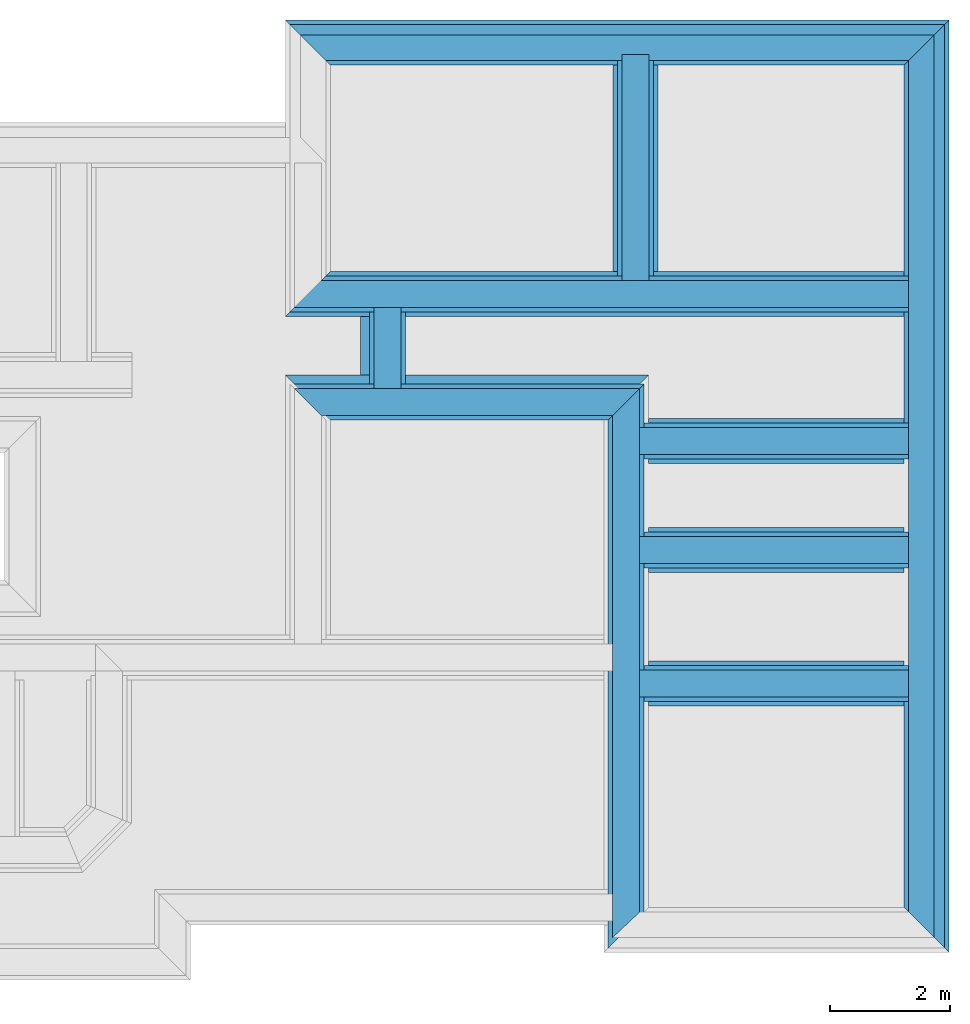
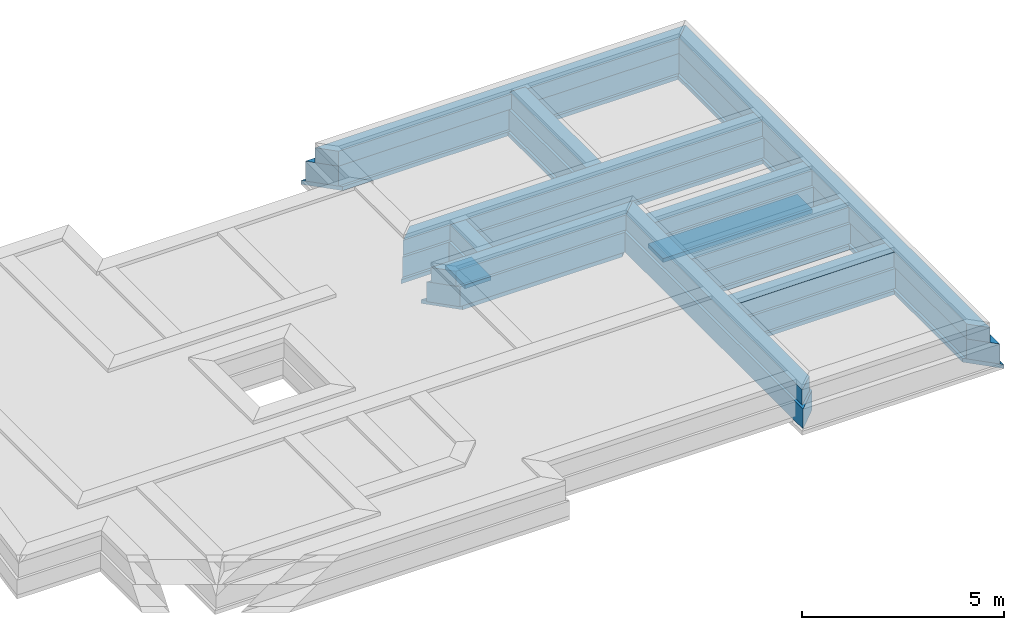
# One storey, part 4 of 6: 29 walls.
"""IFC4X3_ADD2 building model written with IfcOpenShell, lengths in metres."""

import ifcopenshell
import ifcopenshell.guid

model = None  # the IFC model being written
_history = None  # IfcOwnerHistory: only IFC2X3 demands one
_inside = {}  # id of a spatial element -> (the spatial element, [elements in it])
_under = {}  # id of a project, library or spatial element -> (it, [spatial elements below it])
_declared = {}  # id of a project -> (the project, [libraries it declares])
_typed = {}  # id of a type object -> (the type object, [elements of that type])
_made_of = {}  # id of a material, layer set ... -> (it, [elements and type objects made of it])


def new_model(schema):
    """Start an empty IFC model of exactly this schema.

    Asked for "IFC4X3", IfcOpenShell would pick the latest addendum, in which some entities
    have other attributes; the version numbers below select the first issue.
    IFC2X3 requires an IfcOwnerHistory on every rooted entity: one is made here for all.
    """
    global model, _history
    if schema == "IFC4X3":
        model = ifcopenshell.file(schema_version=(4, 3, 0, 0))
    else:
        model = ifcopenshell.file(schema=schema)
    _inside.clear()
    _under.clear()
    _declared.clear()
    _typed.clear()
    _made_of.clear()
    _history = None
    if model.schema == "IFC2X3":
        org = make("IfcOrganization", Name="unknown")
        user = make(
            "IfcPersonAndOrganization",
            ThePerson=make("IfcPerson", FamilyName="unknown"),
            TheOrganization=org,
        )
        app = make(
            "IfcApplication",
            ApplicationDeveloper=org,
            Version="unknown",
            ApplicationFullName="unknown",
            ApplicationIdentifier="unknown",
        )
        _history = make(
            "IfcOwnerHistory",
            OwningUser=user,
            OwningApplication=app,
            ChangeAction="ADDED",
            CreationDate=0,
        )
    return model


def make(cls, **values):
    """One entity of the class cls with the attributes given. An attribute that is None is left unset."""
    return model.create_entity(
        cls, **{name: value for name, value in values.items() if value is not None}
    )


def entity(cls, *values):
    """Any entity or typed value of the class cls, its attributes in the order of the schema. None: left unset."""
    e = model.create_entity(cls)
    for i, value in enumerate(values):
        if value is not None:
            e[i] = value
    return e


def rooted(cls, **values):
    """An entity with a GlobalId (a new one), such as an element, a storey or a relation."""
    return make(cls, GlobalId=ifcopenshell.guid.new(), OwnerHistory=_history, **values)


def si_unit(unit_type, name, prefix=None):
    """IfcSIUnit, for example si_unit("LENGTHUNIT", "METRE", prefix="MILLI")."""
    return make("IfcSIUnit", UnitType=unit_type, Prefix=prefix, Name=name)


def converted_unit(unit_type, name, factor, base, dimensions=None, offset=None):
    """IfcConversionBasedUnit, such as the inch: factor (a typed value) times the base unit."""
    return make(
        "IfcConversionBasedUnit"
        if offset is None
        else "IfcConversionBasedUnitWithOffset",
        ConversionOffset=offset,
        Dimensions=None
        if dimensions is None
        else entity("IfcDimensionalExponents", *dimensions),
        UnitType=unit_type,
        Name=name,
        ConversionFactor=make(
            "IfcMeasureWithUnit", ValueComponent=factor, UnitComponent=base
        ),
    )


def assignment(units):
    """IfcUnitAssignment: the units of a project."""
    return None if units is None else make("IfcUnitAssignment", Units=units)


def point(xyz):
    """IfcCartesianPoint."""
    return None if xyz is None else make("IfcCartesianPoint", Coordinates=xyz)


def direction(xyz):
    """IfcDirection."""
    return None if xyz is None else make("IfcDirection", DirectionRatios=xyz)


def frame(location, z_axis=None, x_axis=None):
    """IfcAxis2Placement3D, a coordinate frame: its origin and axes. An axis left out is left unset."""
    return make(
        "IfcAxis2Placement3D",
        Location=point(location),
        Axis=direction(z_axis),
        RefDirection=direction(x_axis),
    )


def frame_2d(location, x_axis=None):
    """IfcAxis2Placement2D, a coordinate frame in the plane: its origin and x axis."""
    return make(
        "IfcAxis2Placement2D", Location=point(location), RefDirection=direction(x_axis)
    )


def origin_with_axes():
    """The frame at (0, 0, 0) with the z axis (0, 0, 1) and the x axis (1, 0, 0) written out."""
    return frame((0.0, 0.0, 0.0), z_axis=(0.0, 0.0, 1.0), x_axis=(1.0, 0.0, 0.0))


def origin_2d_with_axis():
    """The frame at (0, 0) in the plane with the x axis (1, 0) written out."""
    return frame_2d((0.0, 0.0), x_axis=(1.0, 0.0))


def place(relative_to, where):
    """IfcLocalPlacement: puts the frame where relative to a parent placement (None: the world)."""
    return make(
        "IfcLocalPlacement", PlacementRelTo=relative_to, RelativePlacement=where
    )


def context(
    kind, dimensions, precision=None, world=None, true_north=None, identifier=None
):
    """IfcGeometricRepresentationContext, for example the 3D "Model" context."""
    return make(
        "IfcGeometricRepresentationContext",
        ContextIdentifier=identifier,
        ContextType=kind,
        CoordinateSpaceDimension=dimensions,
        Precision=precision,
        WorldCoordinateSystem=world,
        TrueNorth=true_north,
    )


def subcontext(parent, identifier, kind, view, scale=None):
    """IfcGeometricRepresentationSubContext, for example "Body" below "Model"."""
    return make(
        "IfcGeometricRepresentationSubContext",
        ContextIdentifier=identifier,
        ContextType=kind,
        ParentContext=parent,
        TargetScale=scale,
        TargetView=view,
    )


def project(units=None, contexts=None):
    """IfcProject with its units and contexts."""
    return rooted(
        "IfcProject",
        Name="project",
        RepresentationContexts=contexts,
        UnitsInContext=assignment(units),
    )


def spatial(cls, under=None, at=None, **own):
    """A site, building, storey or space (cls), placed at a placement, below another one or the project."""
    s = rooted(cls, ObjectPlacement=at, **own)
    if under is not None:
        _under.setdefault(under.id(), (under, []))[1].append(s)
    return s


def point_list(points):
    """IfcCartesianPointList2D or 3D."""
    cls = (
        "IfcCartesianPointList2D" if len(points[0]) == 2 else "IfcCartesianPointList3D"
    )
    return make(cls, CoordList=points)


def line(*indices):
    """IfcLineIndex: a straight run through numbered points of an indexed curve."""
    return model.create_entity("IfcLineIndex", indices)


def indexed_curve(points, segments=None, self_intersect=None):
    """IfcIndexedPolyCurve: lines and arcs through numbered points (the first is 1)."""
    return make(
        "IfcIndexedPolyCurve",
        Points=point_list(points),
        Segments=segments,
        SelfIntersect=self_intersect,
    )


def outline(outer, holes=None, kind="AREA"):
    """IfcArbitraryClosedProfileDef: a profile drawn as a closed curve; with holes, ...WithVoids."""
    if holes is None:
        return make("IfcArbitraryClosedProfileDef", ProfileType=kind, OuterCurve=outer)
    return make(
        "IfcArbitraryProfileDefWithVoids",
        ProfileType=kind,
        OuterCurve=outer,
        InnerCurves=holes,
    )


def extrude(swept, where, along, depth):
    """IfcExtrudedAreaSolid: the profile swept, set in the frame where, extruded along a direction by depth."""
    return make(
        "IfcExtrudedAreaSolid",
        SweptArea=swept,
        Position=where,
        ExtrudedDirection=direction(along),
        Depth=depth,
    )


def shape(context_of_items, identifier, shape_type, items):
    """IfcShapeRepresentation: the items that make up one representation, for example the "Body"."""
    return make(
        "IfcShapeRepresentation",
        ContextOfItems=context_of_items,
        RepresentationIdentifier=identifier,
        RepresentationType=shape_type,
        Items=items,
    )


def material(Name=None, Category=None):
    """IfcMaterial."""
    return make("IfcMaterial", Name=Name, Category=Category)


def layer(
    of_material, thickness, ventilated=None, Name=None, Category=None, Priority=None
):
    """IfcMaterialLayer: one layer of a wall or slab, of a material (None: an air gap)."""
    return make(
        "IfcMaterialLayer",
        Material=of_material,
        LayerThickness=thickness,
        IsVentilated=ventilated,
        Name=Name,
        Category=Category,
        Priority=Priority,
    )


def layer_set(layers, Name=None):
    """IfcMaterialLayerSet."""
    return make("IfcMaterialLayerSet", MaterialLayers=layers, LayerSetName=Name)


def layer_usage(for_layer_set, set_direction, sense, offset, extent=None):
    """IfcMaterialLayerSetUsage: how a layer set lies in its element."""
    return make(
        "IfcMaterialLayerSetUsage",
        ForLayerSet=for_layer_set,
        LayerSetDirection=set_direction,
        DirectionSense=sense,
        OffsetFromReferenceLine=offset,
        ReferenceExtent=extent,
    )


def made_of(thing, what):
    """Note that an element or type object is made of a material, layer set ...; save() writes the relation."""
    if what is not None:
        _made_of.setdefault(what.id(), (what, []))[1].append(thing)
    return thing


def type_object(cls, material=None, **own):
    """A type object (cls), such as IfcWallType, which elements share."""
    return made_of(rooted(cls, **own), material)


def element(
    cls,
    number,
    at=None,
    inside=None,
    cuts=None,
    type_object=None,
    material=None,
    context=None,
    identifier="Body",
    shape_type=None,
    held_by="IfcProductDefinitionShape",
    body=None,
    shapes=None,
    **own,
):
    """One element of the class cls, such as IfcWall. Its Tag is "e" and its number.

    at: its placement. inside: the storey or other place that contains it. cuts: it is an
    opening in that element (IfcRelVoidsElement). A single representation is given by context,
    identifier, shape_type and body (its items); several are given by shapes. held_by: the class
    of the entity that holds the representations. save() writes the other relations.
    """
    e = rooted(cls, Tag="e%d" % number, ObjectPlacement=at, **own)
    if body is not None:
        shapes = [shape(context, identifier, shape_type, body)]
    if shapes is not None:
        e.Representation = make(held_by, Representations=shapes)
    if inside is not None:
        _inside.setdefault(inside.id(), (inside, []))[1].append(e)
    if cuts is not None:
        rooted(
            "IfcRelVoidsElement", RelatingBuildingElement=cuts, RelatedOpeningElement=e
        )
    if type_object is not None:
        _typed.setdefault(type_object.id(), (type_object, []))[1].append(e)
    return made_of(e, material)


def aggregate(whole, parts):
    """IfcRelAggregates: a whole, such as a stair, and the parts it consists of."""
    return rooted("IfcRelAggregates", RelatingObject=whole, RelatedObjects=parts)


def save(model, path):
    """Write the relations noted so far, then the file.

    IfcRelAggregates (storeys below a building ...), IfcRelContainedInSpatialStructure (elements
    in a storey), IfcRelDefinesByType, IfcRelAssociatesMaterial and IfcRelDeclares: one each for
    every whole, place, type object, material and project.
    """
    for whole, parts in _under.values():
        aggregate(whole, parts)
    for where, things in _inside.values():
        rooted(
            "IfcRelContainedInSpatialStructure",
            RelatedElements=things,
            RelatingStructure=where,
        )
    for kind, things in _typed.values():
        rooted("IfcRelDefinesByType", RelatedObjects=things, RelatingType=kind)
    for what, things in _made_of.values():
        rooted("IfcRelAssociatesMaterial", RelatedObjects=things, RelatingMaterial=what)
    for by, libraries in _declared.values():
        rooted("IfcRelDeclares", RelatingContext=by, RelatedDefinitions=libraries)
    model.write(path)


model = new_model("IFC4X3_ADD2")

# Units and contexts
model_context = context("Model", 3, precision=1e-05, world=origin_with_axes())
plan_context = context("Plan", 2, precision=1e-05, world=origin_2d_with_axis())
body_context = subcontext(model_context, "Body", "Model", "MODEL_VIEW")
ifc_project = project(units=[si_unit("VOLUMEUNIT", "CUBIC_METRE"), si_unit("LENGTHUNIT", "METRE"), converted_unit("PLANEANGLEUNIT", "degree", entity("IfcReal", 0.0174532925199433), si_unit("PLANEANGLEUNIT", "RADIAN"), dimensions=[0, 0, 0, 0, 0, 0, 0]), si_unit("AREAUNIT", "SQUARE_METRE")], contexts=[model_context, plan_context])

# Site, building, storey
site_placement = place(None, origin_with_axes())
site = spatial("IfcSite", under=ifc_project, at=site_placement)
building_placement = place(site_placement, origin_with_axes())
building = spatial("IfcBuilding", under=site, at=building_placement, Name="Building")
storey_placement = place(building_placement, frame((0.0, 0.0, -0.870000004768372), z_axis=(0.0, 0.0, 1.0), x_axis=(1.0, 0.0, 0.0)))
storey = spatial("IfcBuildingStorey", under=building, at=storey_placement, Name="Footing")

# Walls
ifc_material_1 = material(Name="Stone", Category="Structure")
ifc_layer_1 = layer(ifc_material_1, 0.449999988079071)
ifc_layer_set_1 = layer_set([ifc_layer_1])
ifc_layer_usage_1 = layer_usage(ifc_layer_set_1, "AXIS2", "POSITIVE", 0.0)
wall_type_1 = type_object("IfcWallType", Name="RRB Basement", PredefinedType="SHEAR", material=ifc_layer_set_1)
wall_1_placement = place(storey_placement, frame((23.9316806793215, 21.8778921531674, 0.719999998807908), z_axis=(0.0, 0.0, 1.0), x_axis=(3.13916473260163e-07, 0.999999999999951, 0.0)))
element("IfcWall", 1, at=wall_1_placement, inside=storey, type_object=wall_type_1, material=ifc_layer_usage_1, Name="Wall", context=body_context, shape_type="SweptSolid", body=[
    extrude(outline(indexed_curve([(0.44999998807909, 0.0), (0.450000117880316, 0.449999988079071), (4.22000942370352, 0.449999988079071), (4.22000939257221, 0.0)], segments=[line(1, 2, 3, 4, 1)])), origin_with_axes(), (0.0, 0.0, 1.0), 0.449999988079071),
])
ifc_layer_usage_2 = layer_usage(ifc_layer_set_1, "AXIS2", "POSITIVE", 0.0)
wall_2_placement = place(storey_placement, frame((23.7750164771225, 15.3793488442897, 0.719999998807908), z_axis=(0.0, 0.0, 1.0), x_axis=(0.999999999999822, -5.960464477538e-07, 0.0)))
element("IfcWall", 2, at=wall_2_placement, inside=storey, type_object=wall_type_1, material=ifc_layer_usage_2, Name="Wall", context=body_context, shape_type="SweptSolid", body=[
    extrude(outline(indexed_curve([(0.0, 0.0), (-9.81330211661044e-08, 0.449999988079071), (4.48665310620748, 0.449999988079071), (4.48665323122998, 0.0)], segments=[line(1, 2, 3, 4, 1)])), origin_with_axes(), (0.0, 0.0, 1.0), 0.449999988079071),
])
ifc_layer_usage_3 = layer_usage(ifc_layer_set_1, "AXIS2", "POSITIVE", 0.0)
wall_3_placement = place(storey_placement, frame((18.4541816711426, 21.8778954520824, 0.719999998807908), z_axis=(0.0, 0.0, 1.0), x_axis=(0.999999999999822, -5.960464477538e-07, 0.0)))
element("IfcWall", 3, at=wall_3_placement, inside=storey, type_object=wall_type_1, material=ifc_layer_usage_3, Name="Wall", context=body_context, shape_type="SweptSolid", body=[
    extrude(outline(indexed_curve([(-0.449999988079037, 0.0), (5.60801341516185e-08, 0.449999988079071), (9.80748997480777, 0.449999988079071), (9.80749009981741, 0.0)], segments=[line(1, 2, 3, 4, 1)])), origin_with_axes(), (0.0, 0.0, 1.0), 0.449999988079071),
])
ifc_layer_usage_4 = layer_usage(ifc_layer_set_1, "AXIS2", "POSITIVE", 0.0)
wall_4_placement = place(storey_placement, frame((23.7750149557985, 11.3693475723266, 0.719999998807908), z_axis=(0.0, 0.0, 1.0), x_axis=(3.13916473260163e-07, 0.999999999999951, 0.0)))
element("IfcWall", 4, at=wall_4_placement, inside=storey, type_object=wall_type_1, material=ifc_layer_usage_4, Name="Wall", context=body_context, shape_type="SweptSolid", body=[
    extrude(outline(indexed_curve([(0.42500000074508, 0.0), (1.47028964871403e-07, 0.449999988079071), (8.70354421117045, 0.449999988079071), (9.15354410546069, 0.0)], segments=[line(1, 2, 3, 4, 1)])), origin_with_axes(), (0.0, 0.0, 1.0), 0.449999988079071),
])
ifc_layer_usage_5 = layer_usage(ifc_layer_set_1, "AXIS2", "POSITIVE", 0.0)
wall_5_placement = place(storey_placement, frame((23.7750180072631, 19.429594129323, 0.719999998807908), z_axis=(0.0, 0.0, 1.0), x_axis=(0.999999999999822, -5.960464477538e-07, 0.0)))
element("IfcWall", 5, at=wall_5_placement, inside=storey, type_object=wall_type_1, material=ifc_layer_usage_5, Name="Wall", context=body_context, shape_type="SweptSolid", body=[
    extrude(outline(indexed_curve([(0.0, 0.0), (-9.81330211661046e-08, 0.449999988079071), (4.48665286418751, 0.449999988079071), (4.48665298921001, 0.0)], segments=[line(1, 2, 3, 4, 1)])), origin_with_axes(), (0.0, 0.0, 1.0), 0.449999988079071),
])
ifc_layer_usage_6 = layer_usage(ifc_layer_set_1, "AXIS2", "POSITIVE", 0.0)
wall_6_placement = place(storey_placement, frame((19.7916831970215, 20.0728931427002, 0.719999998807908), z_axis=(0.0, 0.0, 1.0), x_axis=(3.13916473260163e-07, 0.999999999999951, 0.0)))
element("IfcWall", 6, at=wall_6_placement, inside=storey, type_object=wall_type_1, material=ifc_layer_usage_6, Name="Wall", context=body_context, shape_type="SweptSolid", body=[
    extrude(outline(indexed_curve([(0.449999988079079, 0.0), (0.450000081867921, 0.449999988079071), (1.80500099995072, 0.449999988079071), (1.80500087014949, 0.0)], segments=[line(1, 2, 3, 4, 1)])), origin_with_axes(), (0.0, 0.0, 1.0), 0.449999988079071),
])
ifc_layer_usage_7 = layer_usage(ifc_layer_set_1, "AXIS2", "POSITIVE", 0.0)
wall_7_placement = place(storey_placement, frame((23.7750173195989, 17.6093636453146, 0.719999998807908), z_axis=(0.0, 0.0, 1.0), x_axis=(0.999999999999822, -5.960464477538e-07, 0.0)))
element("IfcWall", 7, at=wall_7_placement, inside=storey, type_object=wall_type_1, material=ifc_layer_usage_7, Name="Wall", context=body_context, shape_type="SweptSolid", body=[
    extrude(outline(indexed_curve([(0.0, 0.0), (-9.81330211661044e-08, 0.449999988079071), (4.48665297295429, 0.449999988079071), (4.48665309797679, 0.0)], segments=[line(1, 2, 3, 4, 1)])), origin_with_axes(), (0.0, 0.0, 1.0), 0.449999988079071),
])
ifc_layer_usage_8 = layer_usage(ifc_layer_set_1, "AXIS2", "POSITIVE", 0.0)
wall_8_placement = place(storey_placement, frame((18.4666819764865, 20.0728944624433, 0.719999998807908), z_axis=(0.0, 0.0, 1.0), x_axis=(0.999999999999822, -5.960464477538e-07, 0.0)))
element("IfcWall", 8, at=wall_8_placement, inside=storey, type_object=wall_type_1, material=ifc_layer_usage_8, Name="Wall", context=body_context, shape_type="SweptSolid", body=[
    extrude(outline(indexed_curve([(0.0, 0.0), (-0.450000108145878, 0.449999988079071), (5.30833617205419, 0.449999988079071), (4.85833628210813, 0.0)], segments=[line(1, 2, 3, 4, 1)])), origin_with_axes(), (0.0, 0.0, 1.0), 0.449999988079071),
])
ifc_material_2 = material(Name="Plaster", Category="Finishes")
ifc_layer_2 = layer(ifc_material_2, 0.00999999977648258)
ifc_layer_3 = layer(ifc_material_1, 0.405000001192093)
ifc_layer_4 = layer(ifc_material_2, 0.00999999977648258)
ifc_layer_set_2 = layer_set([ifc_layer_2, ifc_layer_3, ifc_layer_4])
ifc_layer_usage_9 = layer_usage(ifc_layer_set_2, "AXIS2", "POSITIVE", 0.0)
wall_type_2 = type_object("IfcWallType", Name="RRB Basement Flush 425", PredefinedType="SHEAR", material=ifc_layer_set_2)
wall_9_placement = place(storey_placement, frame((28.6866732177093, 26.4228973778099, 0.719999998807908), z_axis=(0.0, 0.0, 1.0), x_axis=(-0.999999999999924, 3.89414367418765e-07, 0.0)))
element("IfcWall", 9, at=wall_9_placement, inside=storey, type_object=wall_type_2, material=ifc_layer_usage_9, Name="Wall", context=body_context, shape_type="SweptSolid", body=[
    extrude(outline(indexed_curve([(0.0, 0.0), (0.424999970499032, 0.425000000745058), (10.1449899350157, 0.425000000745058), (10.5699904372669, 0.0)], segments=[line(1, 2, 3, 4, 1)])), origin_with_axes(), (0.0, 0.0, 1.0), 0.449999988079071),
])
ifc_layer_usage_10 = layer_usage(ifc_layer_set_2, "AXIS2", "POSITIVE", 0.0)
wall_10_placement = place(storey_placement, frame((28.6866684273878, 11.369344425688, 0.719999998807908), z_axis=(0.0, 0.0, 1.0), x_axis=(3.13916473260163e-07, 0.999999999999951, 0.0)))
element("IfcWall", 10, at=wall_10_placement, inside=storey, type_object=wall_type_2, material=ifc_layer_usage_10, Name="Wall", context=body_context, shape_type="SweptSolid", body=[
    extrude(outline(indexed_curve([(0.0, 0.0), (0.425000139605773, 0.425000000745058), (14.628552980733, 0.425000000745058), (15.0535529521226, 0.0)], segments=[line(1, 2, 3, 4, 1)])), origin_with_axes(), (0.0, 0.0, 1.0), 0.449999988079071),
])
ifc_material_3 = material(Name="Wall")
ifc_layer_5 = layer(ifc_material_3, 0.600000023841858, Name="concrete")
ifc_layer_set_3 = layer_set([ifc_layer_5], Name="concrete")
ifc_layer_usage_11 = layer_usage(ifc_layer_set_3, "AXIS2", "POSITIVE", 0.0)
wall_type_3 = type_object("IfcWallType", Name="RRB Foundation", PredefinedType="SHEAR", material=ifc_layer_set_3)
wall_11_placement = place(storey_placement, frame((24.0066795584563, 21.8028932526459, 0.120000004768372), z_axis=(0.0, 0.0, 1.0), x_axis=(3.13916473260163e-07, 0.999999999999951, 0.0)))
element("IfcWall", 11, at=wall_11_placement, inside=storey, type_object=wall_type_3, material=ifc_layer_usage_11, Name="Wall", context=body_context, shape_type="SweptSolid", body=[
    extrude(outline(indexed_curve([(0.600000023841883, 0.0), (0.600000196937945, 0.600000023841858), (4.19500713718583, 0.600000023841858), (4.19500709570516, 0.0)], segments=[line(1, 2, 3, 4, 1)])), origin_with_axes(), (0.0, 0.0, 1.0), 0.600000023841858),
])
ifc_layer_usage_12 = layer_usage(ifc_layer_set_3, "AXIS2", "POSITIVE", 0.0)
wall_12_placement = place(storey_placement, frame((23.8500150770871, 15.3043489903219, 0.120000004768372), z_axis=(0.0, 0.0, 1.0), x_axis=(0.999999999999822, -5.960464477538e-07, 0.0)))
element("IfcWall", 12, at=wall_12_placement, inside=storey, type_object=wall_type_3, material=ifc_layer_usage_12, Name="Wall", context=body_context, shape_type="SweptSolid", body=[
    extrude(outline(indexed_curve([(0.0, 0.0), (-1.64834769827048e-07, 0.600000023841858), (4.41165560377788, 0.600000023841858), (4.41165577052876, 0.0)], segments=[line(1, 2, 3, 4, 1)])), origin_with_axes(), (0.0, 0.0, 1.0), 0.600000023841858),
])
ifc_layer_usage_13 = layer_usage(ifc_layer_set_3, "AXIS2", "POSITIVE", 0.0)
wall_13_placement = place(storey_placement, frame((18.5416813132168, 21.8028965443377, 0.120000004768372), z_axis=(0.0, 0.0, 1.0), x_axis=(0.999999999999822, -5.960464477538e-07, 0.0)))
element("IfcWall", 13, at=wall_13_placement, inside=storey, type_object=wall_type_3, material=ifc_layer_usage_13, Name="Wall", context=body_context, shape_type="SweptSolid", body=[
    extrude(outline(indexed_curve([(-0.60000002384188, 0.0), (-1.61120317371057e-07, 0.600000023841858), (9.71999143525005, 0.600000023841858), (9.71999160198862, 0.0)], segments=[line(1, 2, 3, 4, 1)])), origin_with_axes(), (0.0, 0.0, 1.0), 0.600000023841858),
])
ifc_layer_usage_14 = layer_usage(ifc_layer_set_3, "AXIS2", "POSITIVE", 0.0)
wall_14_placement = place(storey_placement, frame((23.8500163785197, 19.3545952290297, 0.120000004768372), z_axis=(0.0, 0.0, 1.0), x_axis=(0.999999999999822, -5.960464477538e-07, 0.0)))
element("IfcWall", 14, at=wall_14_placement, inside=storey, type_object=wall_type_3, material=ifc_layer_usage_14, Name="Wall", context=body_context, shape_type="SweptSolid", body=[
    extrude(outline(indexed_curve([(0.0, 0.0), (-1.64834769819655e-07, 0.600000023841858), (4.41165559102303, 0.600000023841858), (4.4116557577616, 0.0)], segments=[line(1, 2, 3, 4, 1)])), origin_with_axes(), (0.0, 0.0, 1.0), 0.600000023841858),
])
ifc_layer_usage_15 = layer_usage(ifc_layer_set_3, "AXIS2", "POSITIVE", 0.0)
wall_15_placement = place(storey_placement, frame((19.8666820526127, 19.9978935266985, 0.120000004768372), z_axis=(0.0, 0.0, 1.0), x_axis=(3.13916473260163e-07, 0.999999999999951, 0.0)))
element("IfcWall", 15, at=wall_15_placement, inside=storey, type_object=wall_type_3, material=ifc_layer_usage_15, Name="Wall", context=body_context, shape_type="SweptSolid", body=[
    extrude(outline(indexed_curve([(0.600000023841884, 0.0), (0.600000200488681, 0.600000023841858), (1.8050023934961, 0.600000023841858), (1.80500222042779, 0.0)], segments=[line(1, 2, 3, 4, 1)])), origin_with_axes(), (0.0, 0.0, 1.0), 0.600000023841858),
])
ifc_layer_usage_16 = layer_usage(ifc_layer_set_3, "AXIS2", "POSITIVE", 0.0)
wall_16_placement = place(storey_placement, frame((23.8500157936399, 17.5343647450212, 0.120000004768372), z_axis=(0.0, 0.0, 1.0), x_axis=(0.999999999999822, -5.960464477538e-07, 0.0)))
element("IfcWall", 16, at=wall_16_placement, inside=storey, type_object=wall_type_3, material=ifc_layer_usage_16, Name="Wall", context=body_context, shape_type="SweptSolid", body=[
    extrude(outline(indexed_curve([(0.0, 0.0), (-1.64834769833533e-07, 0.600000023841858), (4.41165559679863, 0.600000023841858), (4.4116557635372, 0.0)], segments=[line(1, 2, 3, 4, 1)])), origin_with_axes(), (0.0, 0.0, 1.0), 0.600000023841858),
])
ifc_layer_usage_17 = layer_usage(ifc_layer_set_3, "AXIS2", "POSITIVE", 0.0)
wall_17_placement = place(storey_placement, frame((23.8500137564538, 11.1943474262957, 0.120000004768372), z_axis=(0.0, 0.0, 1.0), x_axis=(3.13916473260163e-07, 0.999999999999951, 0.0)))
element("IfcWall", 17, at=wall_17_placement, inside=storey, type_object=wall_type_3, material=ifc_layer_usage_17, Name="Wall", context=body_context, shape_type="SweptSolid", body=[
    extrude(outline(indexed_curve([(0.600000023841889, 0.0), (1.9550465227668e-07, 0.600000023841858), (8.8035438529559, 0.600000023841858), (9.40354370015098, 0.0)], segments=[line(1, 2, 3, 4, 1)])), origin_with_axes(), (0.0, 0.0, 1.0), 0.600000023841858),
])
ifc_layer_usage_18 = layer_usage(ifc_layer_set_3, "AXIS2", "POSITIVE", 0.0)
wall_18_placement = place(storey_placement, frame((18.5416808073643, 19.9978943318125, 0.120000004768372), z_axis=(0.0, 0.0, 1.0), x_axis=(0.999999999999822, -5.960464477538e-07, 0.0)))
element("IfcWall", 18, at=wall_18_placement, inside=storey, type_object=wall_type_3, material=ifc_layer_usage_18, Name="Wall", context=body_context, shape_type="SweptSolid", body=[
    extrude(outline(indexed_curve([(0.0, 0.0), (-0.600000183930945, 0.600000023841858), (5.30833561302661, 0.600000023841858), (4.7083357540195, 0.0)], segments=[line(1, 2, 3, 4, 1)])), origin_with_axes(), (0.0, 0.0, 1.0), 0.600000023841858),
])
ifc_layer_usage_19 = layer_usage(ifc_layer_set_3, "AXIS2", "POSITIVE", 0.0)
wall_19_placement = place(storey_placement, frame((28.8616744645718, 26.5978985124831, 0.120000004768372), z_axis=(0.0, 0.0, 1.0), x_axis=(-0.999999999999924, 3.89414367418765e-07, 0.0)))
element("IfcWall", 19, at=wall_19_placement, inside=storey, type_object=wall_type_3, material=ifc_layer_usage_19, Name="Wall", context=body_context, shape_type="SweptSolid", body=[
    extrude(outline(indexed_curve([(0.0, 0.0), (0.599999981082541, 0.600000023841858), (10.3199915436642, 0.600000023841858), (10.9199916047727, 0.0)], segments=[line(1, 2, 3, 4, 1)])), origin_with_axes(), (0.0, 0.0, 1.0), 0.600000023841858),
])
ifc_layer_usage_20 = layer_usage(ifc_layer_set_3, "AXIS2", "POSITIVE", 0.0)
wall_20_placement = place(storey_placement, frame((28.8616695639489, 11.1943442232811, 0.120000004768372), z_axis=(0.0, 0.0, 1.0), x_axis=(3.13916473260163e-07, 0.999999999999951, 0.0)))
element("IfcWall", 20, at=wall_20_placement, inside=storey, type_object=wall_type_3, material=ifc_layer_usage_20, Name="Wall", context=body_context, shape_type="SweptSolid", body=[
    extrude(outline(indexed_curve([(0.0, 0.0), (0.600000219346542, 0.600000023841858), (14.8035543096255, 0.600000023841858), (15.4035542919589, 0.0)], segments=[line(1, 2, 3, 4, 1)])), origin_with_axes(), (0.0, 0.0, 1.0), 0.600000023841858),
])
ifc_layer_6 = layer(ifc_material_3, 0.75)
ifc_layer_set_4 = layer_set([ifc_layer_6])
ifc_layer_usage_21 = layer_usage(ifc_layer_set_4, "AXIS2", "POSITIVE", 0.0)
wall_type_4 = type_object("IfcWallType", Name="PCC 120mm", PredefinedType="SHEAR", material=ifc_layer_set_4)
wall_21_placement = place(storey_placement, frame((24.0816802712711, 21.7278931602364, 0.0), z_axis=(0.0, 0.0, 1.0), x_axis=(3.13916473260163e-07, 0.999999999999951, 0.0)))
element("IfcWall", 21, at=wall_21_placement, inside=storey, type_object=wall_type_4, material=ifc_layer_usage_21, Name="Wall", context=body_context, shape_type="SweptSolid", body=[
    extrude(outline(indexed_curve([(0.750000000000031, 0.0), (0.750000216335415, 0.75), (4.19500832754658, 0.75), (4.19500827566106, 0.0)], segments=[line(1, 2, 3, 4, 1)])), origin_with_axes(), (0.0, 0.0, 1.0), 0.119999997317791),
])
ifc_layer_usage_22 = layer_usage(ifc_layer_set_4, "AXIS2", "POSITIVE", 0.0)
wall_22_placement = place(storey_placement, frame((28.9366757609006, 26.6728995759628, 0.0), z_axis=(0.0, 0.0, 1.0), x_axis=(-0.999999999999924, 3.89414367418765e-07, 0.0)))
element("IfcWall", 22, at=wall_22_placement, inside=storey, type_object=wall_type_4, material=ifc_layer_usage_22, Name="Wall", context=body_context, shape_type="SweptSolid", body=[
    extrude(outline(indexed_curve([(0.0, 0.0), (0.749999954027897, 0.75), (10.3199920334468, 0.75), (11.069992080249, 0.0)], segments=[line(1, 2, 3, 4, 1)])), origin_with_axes(), (0.0, 0.0, 1.0), 0.119999997317791),
])
ifc_layer_usage_23 = layer_usage(ifc_layer_set_4, "AXIS2", "POSITIVE", 0.0)
wall_23_placement = place(storey_placement, frame((28.9366708072764, 11.1193440653482, 0.0), z_axis=(0.0, 0.0, 1.0), x_axis=(3.13916473260163e-07, 0.999999999999951, 0.0)))
element("IfcWall", 23, at=wall_23_placement, inside=storey, type_object=wall_type_4, material=ifc_layer_usage_23, Name="Wall", context=body_context, shape_type="SweptSolid", body=[
    extrude(outline(indexed_curve([(0.0, 0.0), (0.750000244380841, 0.75), (14.8035555625009, 0.75), (15.5535555106153, 0.0)], segments=[line(1, 2, 3, 4, 1)])), origin_with_axes(), (0.0, 0.0, 1.0), 0.119999997317791),
])
ifc_layer_usage_24 = layer_usage(ifc_layer_set_4, "AXIS2", "POSITIVE", 0.0)
wall_24_placement = place(storey_placement, frame((19.8666819737333, 19.9978927276556, 0.0), z_axis=(0.0, 0.0, 1.0), x_axis=(3.13916473260163e-07, 0.999999999999951, 0.0)))
element("IfcWall", 24, at=wall_24_placement, inside=storey, type_object=wall_type_4, material=ifc_layer_usage_24, Name="Wall", context=body_context, shape_type="SweptSolid", body=[
    extrude(outline(indexed_curve([(0.750000000000032, 0.0), (0.750000220808519, 0.75), (1.73000318787769, 0.75), (1.7300029715423, 0.0)], segments=[line(1, 2, 3, 4, 1)])), origin_with_axes(), (0.0, 0.0, 1.0), 0.119999997317791),
])
ifc_layer_usage_25 = layer_usage(ifc_layer_set_4, "AXIS2", "POSITIVE", 0.0)
wall_25_placement = place(storey_placement, frame((23.9250157778293, 15.2293487665903, 0.0), z_axis=(0.0, 0.0, 1.0), x_axis=(0.999999999999822, -5.960464477538e-07, 0.0)))
element("IfcWall", 25, at=wall_25_placement, inside=storey, type_object=wall_type_4, material=ifc_layer_usage_25, Name="Wall", context=body_context, shape_type="SweptSolid", body=[
    extrude(outline(indexed_curve([(0.0, 0.0), (-2.06090370372681e-07, 0.75), (4.26165612841869, 0.75), (4.26165633687251, 0.0)], segments=[line(1, 2, 3, 4, 1)])), origin_with_axes(), (0.0, 0.0, 1.0), 0.119999997317791),
])
ifc_layer_usage_26 = layer_usage(ifc_layer_set_4, "AXIS2", "POSITIVE", 0.0)
wall_26_placement = place(storey_placement, frame((23.9250164942423, 17.4593635957983, 0.0), z_axis=(0.0, 0.0, 1.0), x_axis=(0.999999999999822, -5.960464477538e-07, 0.0)))
element("IfcWall", 26, at=wall_26_placement, inside=storey, type_object=wall_type_4, material=ifc_layer_usage_26, Name="Wall", context=body_context, shape_type="SweptSolid", body=[
    extrude(outline(indexed_curve([(0.0, 0.0), (-2.0609037037268e-07, 0.75), (4.26165612139124, 0.75), (4.26165632984506, 0.0)], segments=[line(1, 2, 3, 4, 1)])), origin_with_axes(), (0.0, 0.0, 1.0), 0.119999997317791),
])
ifc_layer_usage_27 = layer_usage(ifc_layer_set_4, "AXIS2", "POSITIVE", 0.0)
wall_27_placement = place(storey_placement, frame((23.9250164031982, 19.2795944213867, 4.44089209850063e-16), z_axis=(0.0, 0.0, 1.0), x_axis=(0.999999999999822, -5.960464477538e-07, 0.0)))
element("IfcWall", 27, at=wall_27_placement, inside=storey, type_object=wall_type_4, material=ifc_layer_usage_27, Name="Wall", context=body_context, shape_type="SweptSolid", body=[
    extrude(outline(indexed_curve([(0.0, 0.0), (-2.06090370372681e-07, 0.75), (4.26165611541895, 0.75), (4.26165632387277, 0.0)], segments=[line(1, 2, 3, 4, 1)])), origin_with_axes(), (0.0, 0.0, 1.0), 0.119999997317791),
])
ifc_layer_usage_28 = layer_usage(ifc_layer_set_4, "AXIS2", "POSITIVE", 0.0)
wall_28_placement = place(storey_placement, frame((18.6166820635789, 21.7278964521527, 0.0), z_axis=(0.0, 0.0, 1.0), x_axis=(0.999999999999822, -5.960464477538e-07, 0.0)))
element("IfcWall", 28, at=wall_28_placement, inside=storey, type_object=wall_type_4, material=ifc_layer_usage_28, Name="Wall", context=body_context, shape_type="SweptSolid", body=[
    extrude(outline(indexed_curve([(-0.750000000000027, 0.0), (-2.01709705883623e-07, 0.75), (9.56999191034836, 0.75), (9.56999211880218, 0.0)], segments=[line(1, 2, 3, 4, 1)])), origin_with_axes(), (0.0, 0.0, 1.0), 0.119999997317791),
])
ifc_layer_usage_29 = layer_usage(ifc_layer_set_4, "AXIS2", "POSITIVE", 0.0)
wall_29_placement = place(storey_placement, frame((18.6166810963623, 19.9978934880659, 0.0), z_axis=(0.0, 0.0, 1.0), x_axis=(0.999999999999822, -5.960464477538e-07, 0.0)))
element("IfcWall", 29, at=wall_29_placement, inside=storey, type_object=wall_type_4, material=ifc_layer_usage_29, Name="Wall", context=body_context, shape_type="SweptSolid", body=[
    extrude(outline(indexed_curve([(0.0, 0.0), (-0.750000200310215, 0.75), (5.30833600731585, 0.75), (4.55833621340619, 0.0)], segments=[line(1, 2, 3, 4, 1)])), origin_with_axes(), (0.0, 0.0, 1.0), 0.119999997317791),
])

save(model, "model.ifc")
